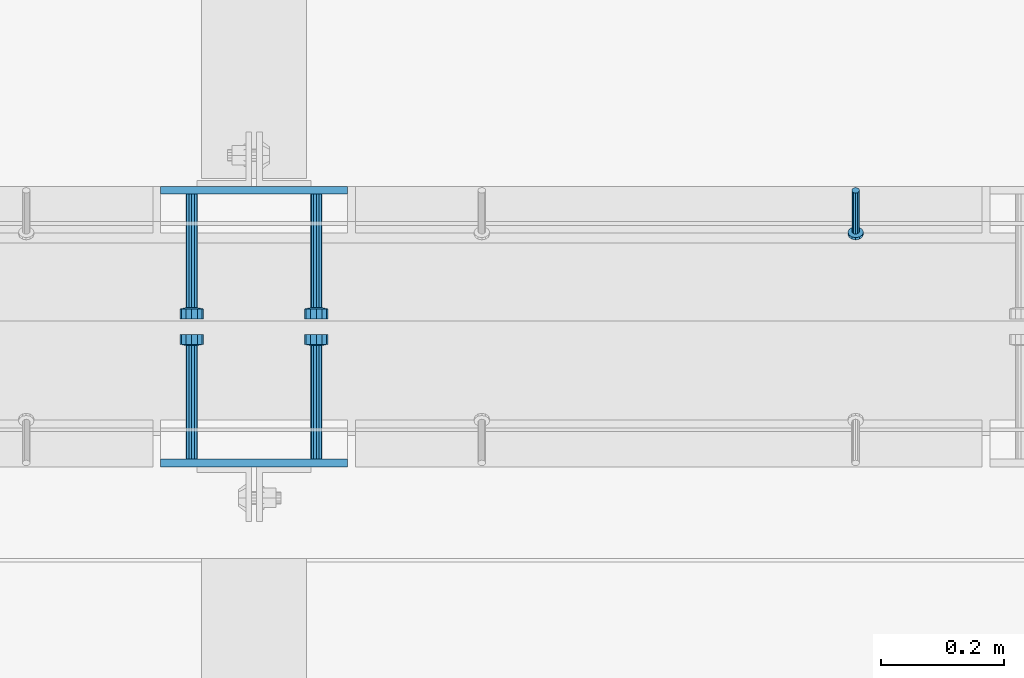
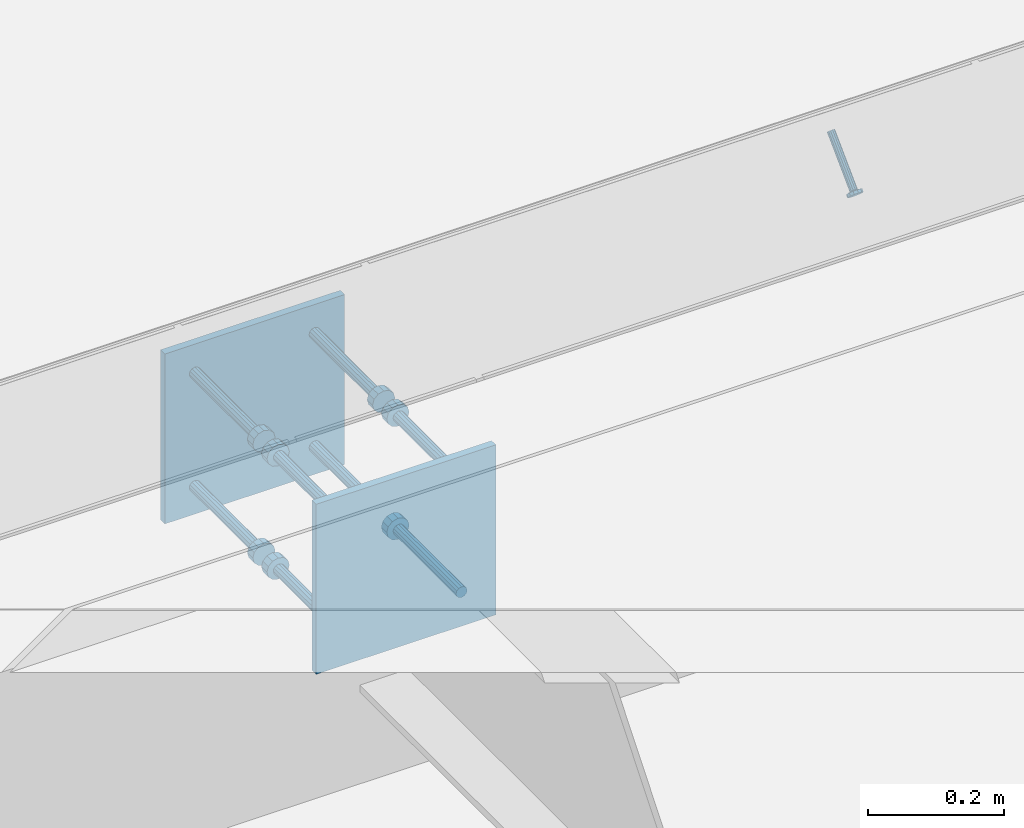
# One storey, part 2011 of 3843: 10 beams, 1 member, 3 elements without a shape of their own.
"""IFC2X3 building model written with IfcOpenShell, lengths in millimetres."""

from ifc_helpers import new_model, si_unit, frame, origin_with_axes, place, context, subcontext, project, spatial, faceted_brep, material, type_object, element, aggregate, save


model = new_model("IFC2X3")

# Units and contexts
model_context = context("Model", 3, precision=1e-05, world=origin_with_axes())
body_context = subcontext(model_context, "Body", "Model", "MODEL_VIEW")
ifc_project = project(units=[si_unit("LENGTHUNIT", "METRE", prefix="MILLI"), si_unit("AREAUNIT", "SQUARE_METRE"), si_unit("VOLUMEUNIT", "CUBIC_METRE"), si_unit("MASSUNIT", "GRAM", prefix="KILO"), si_unit("TIMEUNIT", "SECOND"), si_unit("PLANEANGLEUNIT", "RADIAN"), si_unit("SOLIDANGLEUNIT", "STERADIAN"), si_unit("THERMODYNAMICTEMPERATUREUNIT", "DEGREE_CELSIUS"), si_unit("LUMINOUSINTENSITYUNIT", "LUMEN")], contexts=[model_context])

# Site, building, storey
site_placement = place(None, origin_with_axes())
site = spatial("IfcSite", under=ifc_project, at=site_placement, CompositionType="ELEMENT")
building_placement = place(site_placement, origin_with_axes())
building = spatial("IfcBuilding", under=site, at=building_placement, Name="Undefined", CompositionType="ELEMENT")
storey_placement = place(building_placement, origin_with_axes())
storey = spatial("IfcBuildingStorey", under=building, at=storey_placement, Name="Undefined", CompositionType="ELEMENT", Elevation=0.0)

# Assembly, member
assembly_1_placement = place(storey_placement, origin_with_axes())
assembly_1 = element("IfcElementAssembly", 1, at=assembly_1_placement, inside=storey, Name="ANGLE", AssemblyPlace="NOTDEFINED", PredefinedType="RIGID_FRAME")
ifc_material_1 = material(Name="STEEL/A108")
member_type = type_object("IfcMemberType", PredefinedType="NOTDEFINED")
member_placement = place(assembly_1_placement, frame((45104.0772929978, 20456.5250055596, 30397.4500030518), z_axis=(1.0, 0.0, 0.0), x_axis=(0.0, -0.707106781186548, -0.707106781186548)))
member = element("IfcMember", 2, at=member_placement, type_object=member_type, material=ifc_material_1, Name="HEADED STUD ANCHOR", context=body_context, shape_type="Brep", body=[
    faceted_brep([(7.27595761418343e-12, -3.18000006675175, 5.5), (0.0, -5.49999999998363, 3.1800000667572), (94.4879985803855, -5.50000000011278, 3.1800000667572), (94.4879985803782, -3.18000006687362, 5.5), (0.0, -6.3499999046162, 0.0), (94.4879985803855, -6.34999990474535, 0.0), (0.0, -5.49999999998363, -3.1800000667572), (94.4879985803855, -5.50000000011278, -3.1800000667572), (7.27595761418343e-12, -3.18000006675175, -5.5), (94.4879985803782, -3.18000006687362, -5.5), (7.27595761418343e-12, -1.81898940354586e-12, -6.34999990463257), (94.4879985803782, -1.20053300634027e-10, -6.34999990463257), (0.0, 3.18000006675175, -5.5), (94.4879985803709, 3.18000006663351, -5.5), (7.27595761418343e-12, 5.49999999998363, -3.1800000667572), (94.4879985803709, 5.49999999987267, -3.1800000667572), (7.27595761418343e-12, 6.3499999046162, 0.0), (94.4879985803673, 6.34999990450706, 0.0), (7.27595761418343e-12, 5.49999999998363, 3.1800000667572), (94.4879985803709, 5.49999999987267, 3.1800000667572), (0.0, 3.18000006675175, 5.5), (94.4879985803709, 3.18000006663351, 5.5), (7.27595761418343e-12, -1.81898940354586e-12, 6.34999990463257), (94.4879985803782, -1.20053300634027e-10, 6.34999990463257), (96.5199985498621, -10.9899997712273, 6.34999990463257), (96.5199985498548, -6.34000015270249, 10.9899997711182), (96.5199985498621, -12.6999998093743, 0.0), (96.5199985498621, -10.9899997712273, -6.34999990463257), (96.5199985498548, -6.34000015270249, -10.9899997711182), (96.5199985498475, -1.21872290037572e-10, -12.6899995803833), (96.5199985498402, 6.34000015245874, -10.9899997711182), (96.519998549833, 10.9899997709817, -6.34999990463257), (96.519998549833, 12.6999998091305, 0.0), (96.519998549833, 10.9899997709817, 6.34999990463257), (96.5199985498402, 6.34000015245874, 10.9899997711182), (96.5199985498475, -1.21872290037572e-10, 12.6899995803833), (101.599998473539, -10.9899997712328, 6.34999990463257), (101.599998473532, -6.34000015270976, 10.9899997711182), (101.599998473539, -12.6999998093797, 0.0), (101.599998473539, -10.9899997712328, -6.34999990463257), (101.599998473532, -6.34000015270976, -10.9899997711182), (101.599998473524, -1.29148247651756e-10, -12.6899995803833), (101.599998473517, 6.34000015245329, -10.9899997711182), (101.59999847351, 10.9899997709763, -6.34999990463257), (101.599998473503, 12.6999998091196, 0.0), (101.59999847351, 10.9899997709763, 6.34999990463257), (101.599998473517, 6.34000015245329, 10.9899997711182), (101.599998473524, -1.29148247651756e-10, 12.6899995803833)], [[[0, 1, 2, 3]], [[1, 4, 5, 2]], [[4, 6, 7, 5]], [[6, 8, 9, 7]], [[8, 10, 11, 9]], [[10, 12, 13, 11]], [[12, 14, 15, 13]], [[14, 16, 17, 15]], [[16, 18, 19, 17]], [[18, 20, 21, 19]], [[20, 22, 23, 21]], [[22, 0, 3, 23]], [[22, 20, 18, 16, 14, 12, 10, 8, 6, 4, 1, 0]], [[3, 2, 24, 25]], [[2, 5, 26, 24]], [[5, 7, 27, 26]], [[7, 9, 28, 27]], [[9, 11, 29, 28]], [[11, 13, 30, 29]], [[13, 15, 31, 30]], [[15, 17, 32, 31]], [[17, 19, 33, 32]], [[19, 21, 34, 33]], [[21, 23, 35, 34]], [[23, 3, 25, 35]], [[25, 24, 36, 37]], [[24, 26, 38, 36]], [[26, 27, 39, 38]], [[27, 28, 40, 39]], [[28, 29, 41, 40]], [[29, 30, 42, 41]], [[30, 31, 43, 42]], [[31, 32, 44, 43]], [[32, 33, 45, 44]], [[33, 34, 46, 45]], [[34, 35, 47, 46]], [[35, 25, 37, 47]], [[38, 39, 40, 41, 42, 43, 44, 45, 46, 47, 37, 36]]]),
])
aggregate(assembly_1, [member])

# Assembly, beam
assembly_2_placement = place(storey_placement, origin_with_axes())
assembly_2 = element("IfcElementAssembly", 3, at=assembly_2_placement, inside=storey, Name="EMBED PLATE", AssemblyPlace="NOTDEFINED", PredefinedType="RIGID_FRAME")
ifc_material_2 = material(Name="STEEL/A36")
beam_type_1 = type_object("IfcBeamType", PredefinedType="NOTDEFINED")
beam_1_placement = place(assembly_2_placement, frame((44122.975, 20456.5250030517, 30397.45), z_axis=(-1.0, 0.0, 0.0), x_axis=(0.0, 0.0, -1.0)))
beam_1 = element("IfcBeam", 4, at=beam_1_placement, type_object=beam_type_1, material=ifc_material_2, Name="EMBED PLATE", context=body_context, shape_type="Brep", body=[
    faceted_brep([(-1.0550138540566e-10, 6.34999999999854, -152.400000000664), (1.0550138540566e-10, 6.34999999999854, 152.400000000656), (304.799999999999, 6.34999999999854, 152.400000000001), (304.799999999999, 6.34999999999854, -152.400000000001), (1.0550138540566e-10, -6.34999999999854, 152.400000000656), (304.799999999999, -6.34999999999854, 152.400000000001), (-1.0550138540566e-10, -6.34999999999854, -152.400000000664), (304.799999999999, -6.34999999999854, -152.400000000001)], [[[0, 1, 2, 3]], [[1, 4, 5, 2]], [[4, 6, 7, 5]], [[6, 0, 3, 7]], [[5, 7, 3, 2]], [[6, 4, 1, 0]]]),
])

assembly_3_placement = place(storey_placement, origin_with_axes())
assembly_3 = element("IfcElementAssembly", 5, at=assembly_3_placement, inside=storey, Name="EMBED PLATE", AssemblyPlace="NOTDEFINED", PredefinedType="RIGID_FRAME")
beam_2_placement = place(assembly_3_placement, frame((44122.975, 20012.0249969482, 30397.45), z_axis=(1.0, 0.0, 0.0), x_axis=(0.0, 0.0, -1.0)))
beam_2 = element("IfcBeam", 6, at=beam_2_placement, type_object=beam_type_1, material=ifc_material_2, Name="EMBED PLATE", context=body_context, shape_type="Brep", body=[
    faceted_brep([(-1.0550138540566e-10, 6.34999999999854, -152.400000000664), (1.0550138540566e-10, 6.34999999999854, 152.400000000656), (304.799999999999, 6.34999999999854, 152.400000000001), (304.799999999999, 6.34999999999854, -152.400000000001), (1.0550138540566e-10, -6.34999999999854, 152.400000000656), (304.799999999999, -6.34999999999854, 152.400000000001), (-1.0550138540566e-10, -6.34999999999854, -152.400000000664), (304.799999999999, -6.34999999999854, -152.400000000001)], [[[0, 1, 2, 3]], [[1, 4, 5, 2]], [[4, 6, 7, 5]], [[6, 0, 3, 7]], [[5, 7, 3, 2]], [[6, 4, 1, 0]]]),
])

# Beam
beam_type_2 = type_object("IfcBeamType", PredefinedType="NOTDEFINED")
beam_3_placement = place(assembly_2_placement, frame((44224.575, 20450.1750030517, 30346.65), z_axis=(1.0, 0.0, 0.0), x_axis=(0.0, -1.0, 0.0)))
beam_3 = element("IfcBeam", 7, at=beam_3_placement, type_object=beam_type_2, material=ifc_material_1, Name="HEADED STUD ANCHOR", context=body_context, shape_type="Brep", body=[
    faceted_brep([(0.0, -9.52000045776367, 0.0), (0.0, -8.25, -4.76000022888184), (184.912000000004, -8.25, -4.76000022888184), (184.912000000004, -9.52000045776367, 0.0), (0.0, -4.76000022888184, -8.25), (184.912000000004, -4.76000022888184, -8.25), (0.0, 0.0, -9.52000045776367), (184.912000000004, 0.0, -9.52000045776367), (0.0, 4.76000022888184, -8.25), (184.912000000004, 4.76000022888184, -8.25), (0.0, 8.25, -4.76000022888184), (184.912000000004, 8.25, -4.76000022888184), (0.0, 9.52000045776367, 0.0), (184.912000000004, 9.52000045776367, 0.0), (0.0, 8.25, 4.76000022888184), (184.912000000004, 8.25, 4.76000022888184), (0.0, 4.76000022888184, 8.25), (184.912000000004, 4.76000022888184, 8.25), (0.0, 0.0, 9.52000045776367), (184.912000000004, 0.0, 9.52000045776367), (0.0, -4.76000022888184, 8.25), (184.912000000004, -4.76000022888184, 8.25), (0.0, -8.25, 4.76000022888184), (184.912000000004, -8.25, 4.76000022888184), (186.944000000003, -16.5, -9.52000045776367), (186.944000000003, -19.0499992370605, 0.0), (186.944000000003, -9.52000045776367, -16.5), (186.944000000003, 0.0, -19.0499992370605), (186.944000000003, 9.52000045776367, -16.5), (186.944000000003, 16.5, -9.52000045776367), (186.944000000003, 19.0499992370605, 0.0), (186.944000000003, 16.5, 9.52000045776367), (186.944000000003, 9.52000045776367, 16.5), (186.944000000003, 0.0, 19.0499992370605), (186.944000000003, -9.52000045776367, 16.5), (186.944000000003, -16.5, 9.52000045776367), (203.199999999997, -16.5, -9.52000045776367), (203.199999999997, -19.0499992370605, 0.0), (203.199999999997, -9.52000045776367, -16.5), (203.199999999997, 0.0, -19.0499992370605), (203.199999999997, 9.52000045776367, -16.5), (203.199999999997, 16.5, -9.52000045776367), (203.199999999997, 19.0499992370605, 0.0), (203.199999999997, 16.5, 9.52000045776367), (203.199999999997, 9.52000045776367, 16.5), (203.199999999997, 0.0, 19.0499992370605), (203.199999999997, -9.52000045776367, 16.5), (203.199999999997, -16.5, 9.52000045776367)], [[[0, 1, 2, 3]], [[1, 4, 5, 2]], [[4, 6, 7, 5]], [[6, 8, 9, 7]], [[8, 10, 11, 9]], [[10, 12, 13, 11]], [[12, 14, 15, 13]], [[14, 16, 17, 15]], [[16, 18, 19, 17]], [[18, 20, 21, 19]], [[20, 22, 23, 21]], [[22, 0, 3, 23]], [[22, 20, 18, 16, 14, 12, 10, 8, 6, 4, 1, 0]], [[3, 2, 24, 25]], [[2, 5, 26, 24]], [[5, 7, 27, 26]], [[7, 9, 28, 27]], [[9, 11, 29, 28]], [[11, 13, 30, 29]], [[13, 15, 31, 30]], [[15, 17, 32, 31]], [[17, 19, 33, 32]], [[19, 21, 34, 33]], [[21, 23, 35, 34]], [[23, 3, 25, 35]], [[25, 24, 36, 37]], [[24, 26, 38, 36]], [[26, 27, 39, 38]], [[27, 28, 40, 39]], [[28, 29, 41, 40]], [[29, 30, 42, 41]], [[30, 31, 43, 42]], [[31, 32, 44, 43]], [[32, 33, 45, 44]], [[33, 34, 46, 45]], [[34, 35, 47, 46]], [[35, 25, 37, 47]], [[38, 39, 40, 41, 42, 43, 44, 45, 46, 47, 37, 36]]]),
])

beam_4_placement = place(assembly_2_placement, frame((44224.575, 20450.1750030517, 30143.45), z_axis=(1.0, 0.0, 0.0), x_axis=(0.0, -1.0, 0.0)))
beam_4 = element("IfcBeam", 8, at=beam_4_placement, type_object=beam_type_2, material=ifc_material_1, Name="HEADED STUD ANCHOR", context=body_context, shape_type="Brep", body=[
    faceted_brep([(0.0, -9.52000045776367, 0.0), (0.0, -8.25, -4.76000022888184), (184.912000000004, -8.25, -4.76000022888184), (184.912000000004, -9.52000045776367, 0.0), (0.0, -4.76000022888184, -8.25), (184.912000000004, -4.76000022888184, -8.25), (0.0, 0.0, -9.52000045776367), (184.912000000004, 0.0, -9.52000045776367), (0.0, 4.76000022888184, -8.25), (184.912000000004, 4.76000022888184, -8.25), (0.0, 8.25, -4.76000022888184), (184.912000000004, 8.25, -4.76000022888184), (0.0, 9.52000045776367, 0.0), (184.912000000004, 9.52000045776367, 0.0), (0.0, 8.25, 4.76000022888184), (184.912000000004, 8.25, 4.76000022888184), (0.0, 4.76000022888184, 8.25), (184.912000000004, 4.76000022888184, 8.25), (0.0, 0.0, 9.52000045776367), (184.912000000004, 0.0, 9.52000045776367), (0.0, -4.76000022888184, 8.25), (184.912000000004, -4.76000022888184, 8.25), (0.0, -8.25, 4.76000022888184), (184.912000000004, -8.25, 4.76000022888184), (186.944000000003, -16.5, -9.52000045776367), (186.944000000003, -19.0499992370605, 0.0), (186.944000000003, -9.52000045776367, -16.5), (186.944000000003, 0.0, -19.0499992370605), (186.944000000003, 9.52000045776367, -16.5), (186.944000000003, 16.5, -9.52000045776367), (186.944000000003, 19.0499992370605, 0.0), (186.944000000003, 16.5, 9.52000045776367), (186.944000000003, 9.52000045776367, 16.5), (186.944000000003, 0.0, 19.0499992370605), (186.944000000003, -9.52000045776367, 16.5), (186.944000000003, -16.5, 9.52000045776367), (203.199999999997, -16.5, -9.52000045776367), (203.199999999997, -19.0499992370605, 0.0), (203.199999999997, -9.52000045776367, -16.5), (203.199999999997, 0.0, -19.0499992370605), (203.199999999997, 9.52000045776367, -16.5), (203.199999999997, 16.5, -9.52000045776367), (203.199999999997, 19.0499992370605, 0.0), (203.199999999997, 16.5, 9.52000045776367), (203.199999999997, 9.52000045776367, 16.5), (203.199999999997, 0.0, 19.0499992370605), (203.199999999997, -9.52000045776367, 16.5), (203.199999999997, -16.5, 9.52000045776367)], [[[0, 1, 2, 3]], [[1, 4, 5, 2]], [[4, 6, 7, 5]], [[6, 8, 9, 7]], [[8, 10, 11, 9]], [[10, 12, 13, 11]], [[12, 14, 15, 13]], [[14, 16, 17, 15]], [[16, 18, 19, 17]], [[18, 20, 21, 19]], [[20, 22, 23, 21]], [[22, 0, 3, 23]], [[22, 20, 18, 16, 14, 12, 10, 8, 6, 4, 1, 0]], [[3, 2, 24, 25]], [[2, 5, 26, 24]], [[5, 7, 27, 26]], [[7, 9, 28, 27]], [[9, 11, 29, 28]], [[11, 13, 30, 29]], [[13, 15, 31, 30]], [[15, 17, 32, 31]], [[17, 19, 33, 32]], [[19, 21, 34, 33]], [[21, 23, 35, 34]], [[23, 3, 25, 35]], [[25, 24, 36, 37]], [[24, 26, 38, 36]], [[26, 27, 39, 38]], [[27, 28, 40, 39]], [[28, 29, 41, 40]], [[29, 30, 42, 41]], [[30, 31, 43, 42]], [[31, 32, 44, 43]], [[32, 33, 45, 44]], [[33, 34, 46, 45]], [[34, 35, 47, 46]], [[35, 25, 37, 47]], [[38, 39, 40, 41, 42, 43, 44, 45, 46, 47, 37, 36]]]),
])

beam_5_placement = place(assembly_2_placement, frame((44021.375, 20450.1750030517, 30346.65), z_axis=(1.0, 0.0, 0.0), x_axis=(0.0, -1.0, 0.0)))
beam_5 = element("IfcBeam", 9, at=beam_5_placement, type_object=beam_type_2, material=ifc_material_2, Name="PLATE", context=body_context, shape_type="Brep", body=[
    faceted_brep([(0.0, -9.52000045776367, 0.0), (0.0, -8.25, -4.76000022888184), (184.912000000004, -8.25, -4.76000022888184), (184.912000000004, -9.52000045776367, 0.0), (0.0, -4.76000022888184, -8.25), (184.912000000004, -4.76000022888184, -8.25), (0.0, 0.0, -9.52000045776367), (184.912000000004, 0.0, -9.52000045776367), (0.0, 4.76000022888184, -8.25), (184.912000000004, 4.76000022888184, -8.25), (0.0, 8.25, -4.76000022888184), (184.912000000004, 8.25, -4.76000022888184), (0.0, 9.52000045776367, 0.0), (184.912000000004, 9.52000045776367, 0.0), (0.0, 8.25, 4.76000022888184), (184.912000000004, 8.25, 4.76000022888184), (0.0, 4.76000022888184, 8.25), (184.912000000004, 4.76000022888184, 8.25), (0.0, 0.0, 9.52000045776367), (184.912000000004, 0.0, 9.52000045776367), (0.0, -4.76000022888184, 8.25), (184.912000000004, -4.76000022888184, 8.25), (0.0, -8.25, 4.76000022888184), (184.912000000004, -8.25, 4.76000022888184), (186.944000000003, -16.5, -9.52000045776367), (186.944000000003, -19.0499992370605, 0.0), (186.944000000003, -9.52000045776367, -16.5), (186.944000000003, 0.0, -19.0499992370605), (186.944000000003, 9.52000045776367, -16.5), (186.944000000003, 16.5, -9.52000045776367), (186.944000000003, 19.0499992370605, 0.0), (186.944000000003, 16.5, 9.52000045776367), (186.944000000003, 9.52000045776367, 16.5), (186.944000000003, 0.0, 19.0499992370605), (186.944000000003, -9.52000045776367, 16.5), (186.944000000003, -16.5, 9.52000045776367), (203.199999999997, -16.5, -9.52000045776367), (203.199999999997, -19.0499992370605, 0.0), (203.199999999997, -9.52000045776367, -16.5), (203.199999999997, 0.0, -19.0499992370605), (203.199999999997, 9.52000045776367, -16.5), (203.199999999997, 16.5, -9.52000045776367), (203.199999999997, 19.0499992370605, 0.0), (203.199999999997, 16.5, 9.52000045776367), (203.199999999997, 9.52000045776367, 16.5), (203.199999999997, 0.0, 19.0499992370605), (203.199999999997, -9.52000045776367, 16.5), (203.199999999997, -16.5, 9.52000045776367)], [[[0, 1, 2, 3]], [[1, 4, 5, 2]], [[4, 6, 7, 5]], [[6, 8, 9, 7]], [[8, 10, 11, 9]], [[10, 12, 13, 11]], [[12, 14, 15, 13]], [[14, 16, 17, 15]], [[16, 18, 19, 17]], [[18, 20, 21, 19]], [[20, 22, 23, 21]], [[22, 0, 3, 23]], [[22, 20, 18, 16, 14, 12, 10, 8, 6, 4, 1, 0]], [[3, 2, 24, 25]], [[2, 5, 26, 24]], [[5, 7, 27, 26]], [[7, 9, 28, 27]], [[9, 11, 29, 28]], [[11, 13, 30, 29]], [[13, 15, 31, 30]], [[15, 17, 32, 31]], [[17, 19, 33, 32]], [[19, 21, 34, 33]], [[21, 23, 35, 34]], [[23, 3, 25, 35]], [[25, 24, 36, 37]], [[24, 26, 38, 36]], [[26, 27, 39, 38]], [[27, 28, 40, 39]], [[28, 29, 41, 40]], [[29, 30, 42, 41]], [[30, 31, 43, 42]], [[31, 32, 44, 43]], [[32, 33, 45, 44]], [[33, 34, 46, 45]], [[34, 35, 47, 46]], [[35, 25, 37, 47]], [[38, 39, 40, 41, 42, 43, 44, 45, 46, 47, 37, 36]]]),
])

beam_6_placement = place(assembly_2_placement, frame((44021.375, 20450.1750030517, 30143.45), z_axis=(1.0, 0.0, 0.0), x_axis=(0.0, -1.0, 0.0)))
beam_6 = element("IfcBeam", 10, at=beam_6_placement, type_object=beam_type_2, material=ifc_material_1, Name="HEADED STUD ANCHOR", context=body_context, shape_type="Brep", body=[
    faceted_brep([(0.0, -9.52000045776367, 0.0), (0.0, -8.25, -4.76000022888184), (184.912000000004, -8.25, -4.76000022888184), (184.912000000004, -9.52000045776367, 0.0), (0.0, -4.76000022888184, -8.25), (184.912000000004, -4.76000022888184, -8.25), (0.0, 0.0, -9.52000045776367), (184.912000000004, 0.0, -9.52000045776367), (0.0, 4.76000022888184, -8.25), (184.912000000004, 4.76000022888184, -8.25), (0.0, 8.25, -4.76000022888184), (184.912000000004, 8.25, -4.76000022888184), (0.0, 9.52000045776367, 0.0), (184.912000000004, 9.52000045776367, 0.0), (0.0, 8.25, 4.76000022888184), (184.912000000004, 8.25, 4.76000022888184), (0.0, 4.76000022888184, 8.25), (184.912000000004, 4.76000022888184, 8.25), (0.0, 0.0, 9.52000045776367), (184.912000000004, 0.0, 9.52000045776367), (0.0, -4.76000022888184, 8.25), (184.912000000004, -4.76000022888184, 8.25), (0.0, -8.25, 4.76000022888184), (184.912000000004, -8.25, 4.76000022888184), (186.944000000003, -16.5, -9.52000045776367), (186.944000000003, -19.0499992370605, 0.0), (186.944000000003, -9.52000045776367, -16.5), (186.944000000003, 0.0, -19.0499992370605), (186.944000000003, 9.52000045776367, -16.5), (186.944000000003, 16.5, -9.52000045776367), (186.944000000003, 19.0499992370605, 0.0), (186.944000000003, 16.5, 9.52000045776367), (186.944000000003, 9.52000045776367, 16.5), (186.944000000003, 0.0, 19.0499992370605), (186.944000000003, -9.52000045776367, 16.5), (186.944000000003, -16.5, 9.52000045776367), (203.199999999997, -16.5, -9.52000045776367), (203.199999999997, -19.0499992370605, 0.0), (203.199999999997, -9.52000045776367, -16.5), (203.199999999997, 0.0, -19.0499992370605), (203.199999999997, 9.52000045776367, -16.5), (203.199999999997, 16.5, -9.52000045776367), (203.199999999997, 19.0499992370605, 0.0), (203.199999999997, 16.5, 9.52000045776367), (203.199999999997, 9.52000045776367, 16.5), (203.199999999997, 0.0, 19.0499992370605), (203.199999999997, -9.52000045776367, 16.5), (203.199999999997, -16.5, 9.52000045776367)], [[[0, 1, 2, 3]], [[1, 4, 5, 2]], [[4, 6, 7, 5]], [[6, 8, 9, 7]], [[8, 10, 11, 9]], [[10, 12, 13, 11]], [[12, 14, 15, 13]], [[14, 16, 17, 15]], [[16, 18, 19, 17]], [[18, 20, 21, 19]], [[20, 22, 23, 21]], [[22, 0, 3, 23]], [[22, 20, 18, 16, 14, 12, 10, 8, 6, 4, 1, 0]], [[3, 2, 24, 25]], [[2, 5, 26, 24]], [[5, 7, 27, 26]], [[7, 9, 28, 27]], [[9, 11, 29, 28]], [[11, 13, 30, 29]], [[13, 15, 31, 30]], [[15, 17, 32, 31]], [[17, 19, 33, 32]], [[19, 21, 34, 33]], [[21, 23, 35, 34]], [[23, 3, 25, 35]], [[25, 24, 36, 37]], [[24, 26, 38, 36]], [[26, 27, 39, 38]], [[27, 28, 40, 39]], [[28, 29, 41, 40]], [[29, 30, 42, 41]], [[30, 31, 43, 42]], [[31, 32, 44, 43]], [[32, 33, 45, 44]], [[33, 34, 46, 45]], [[34, 35, 47, 46]], [[35, 25, 37, 47]], [[38, 39, 40, 41, 42, 43, 44, 45, 46, 47, 37, 36]]]),
])

aggregate(assembly_2, [beam_3, beam_4, beam_5, beam_6, beam_1])

beam_7_placement = place(assembly_3_placement, frame((44021.375, 20018.3749969482, 30346.65), z_axis=(-1.0, 0.0, 0.0), x_axis=(0.0, 1.0, 0.0)))
beam_7 = element("IfcBeam", 11, at=beam_7_placement, type_object=beam_type_2, material=ifc_material_1, Name="HEADED STUD ANCHOR", context=body_context, shape_type="Brep", body=[
    faceted_brep([(0.0, -9.52000045776367, 0.0), (0.0, -8.25, -4.76000022888184), (184.912000000004, -8.25, -4.76000022888184), (184.912000000004, -9.52000045776367, 0.0), (0.0, -4.76000022888184, -8.25), (184.912000000004, -4.76000022888184, -8.25), (0.0, 0.0, -9.52000045776367), (184.912000000004, 0.0, -9.52000045776367), (0.0, 4.76000022888184, -8.25), (184.912000000004, 4.76000022888184, -8.25), (0.0, 8.25, -4.76000022888184), (184.912000000004, 8.25, -4.76000022888184), (0.0, 9.52000045776367, 0.0), (184.912000000004, 9.52000045776367, 0.0), (0.0, 8.25, 4.76000022888184), (184.912000000004, 8.25, 4.76000022888184), (0.0, 4.76000022888184, 8.25), (184.912000000004, 4.76000022888184, 8.25), (0.0, 0.0, 9.52000045776367), (184.912000000004, 0.0, 9.52000045776367), (0.0, -4.76000022888184, 8.25), (184.912000000004, -4.76000022888184, 8.25), (0.0, -8.25, 4.76000022888184), (184.912000000004, -8.25, 4.76000022888184), (186.944000000003, -16.5, -9.52000045776367), (186.944000000003, -19.0499992370605, 0.0), (186.944000000003, -9.52000045776367, -16.5), (186.944000000003, 0.0, -19.0499992370605), (186.944000000003, 9.52000045776367, -16.5), (186.944000000003, 16.5, -9.52000045776367), (186.944000000003, 19.0499992370605, 0.0), (186.944000000003, 16.5, 9.52000045776367), (186.944000000003, 9.52000045776367, 16.5), (186.944000000003, 0.0, 19.0499992370605), (186.944000000003, -9.52000045776367, 16.5), (186.944000000003, -16.5, 9.52000045776367), (203.199999999997, -16.5, -9.52000045776367), (203.199999999997, -19.0499992370605, 0.0), (203.199999999997, -9.52000045776367, -16.5), (203.199999999997, 0.0, -19.0499992370605), (203.199999999997, 9.52000045776367, -16.5), (203.199999999997, 16.5, -9.52000045776367), (203.199999999997, 19.0499992370605, 0.0), (203.199999999997, 16.5, 9.52000045776367), (203.199999999997, 9.52000045776367, 16.5), (203.199999999997, 0.0, 19.0499992370605), (203.199999999997, -9.52000045776367, 16.5), (203.199999999997, -16.5, 9.52000045776367)], [[[0, 1, 2, 3]], [[1, 4, 5, 2]], [[4, 6, 7, 5]], [[6, 8, 9, 7]], [[8, 10, 11, 9]], [[10, 12, 13, 11]], [[12, 14, 15, 13]], [[14, 16, 17, 15]], [[16, 18, 19, 17]], [[18, 20, 21, 19]], [[20, 22, 23, 21]], [[22, 0, 3, 23]], [[22, 20, 18, 16, 14, 12, 10, 8, 6, 4, 1, 0]], [[3, 2, 24, 25]], [[2, 5, 26, 24]], [[5, 7, 27, 26]], [[7, 9, 28, 27]], [[9, 11, 29, 28]], [[11, 13, 30, 29]], [[13, 15, 31, 30]], [[15, 17, 32, 31]], [[17, 19, 33, 32]], [[19, 21, 34, 33]], [[21, 23, 35, 34]], [[23, 3, 25, 35]], [[25, 24, 36, 37]], [[24, 26, 38, 36]], [[26, 27, 39, 38]], [[27, 28, 40, 39]], [[28, 29, 41, 40]], [[29, 30, 42, 41]], [[30, 31, 43, 42]], [[31, 32, 44, 43]], [[32, 33, 45, 44]], [[33, 34, 46, 45]], [[34, 35, 47, 46]], [[35, 25, 37, 47]], [[38, 39, 40, 41, 42, 43, 44, 45, 46, 47, 37, 36]]]),
])

beam_8_placement = place(assembly_3_placement, frame((44021.375, 20018.3749969482, 30143.45), z_axis=(-1.0, 0.0, 0.0), x_axis=(0.0, 1.0, 0.0)))
beam_8 = element("IfcBeam", 12, at=beam_8_placement, type_object=beam_type_2, material=ifc_material_1, Name="HEADED STUD ANCHOR", context=body_context, shape_type="Brep", body=[
    faceted_brep([(0.0, -9.52000045776367, 0.0), (0.0, -8.25, -4.76000022888184), (184.912000000004, -8.25, -4.76000022888184), (184.912000000004, -9.52000045776367, 0.0), (0.0, -4.76000022888184, -8.25), (184.912000000004, -4.76000022888184, -8.25), (0.0, 0.0, -9.52000045776367), (184.912000000004, 0.0, -9.52000045776367), (0.0, 4.76000022888184, -8.25), (184.912000000004, 4.76000022888184, -8.25), (0.0, 8.25, -4.76000022888184), (184.912000000004, 8.25, -4.76000022888184), (0.0, 9.52000045776367, 0.0), (184.912000000004, 9.52000045776367, 0.0), (0.0, 8.25, 4.76000022888184), (184.912000000004, 8.25, 4.76000022888184), (0.0, 4.76000022888184, 8.25), (184.912000000004, 4.76000022888184, 8.25), (0.0, 0.0, 9.52000045776367), (184.912000000004, 0.0, 9.52000045776367), (0.0, -4.76000022888184, 8.25), (184.912000000004, -4.76000022888184, 8.25), (0.0, -8.25, 4.76000022888184), (184.912000000004, -8.25, 4.76000022888184), (186.944000000003, -16.5, -9.52000045776367), (186.944000000003, -19.0499992370605, 0.0), (186.944000000003, -9.52000045776367, -16.5), (186.944000000003, 0.0, -19.0499992370605), (186.944000000003, 9.52000045776367, -16.5), (186.944000000003, 16.5, -9.52000045776367), (186.944000000003, 19.0499992370605, 0.0), (186.944000000003, 16.5, 9.52000045776367), (186.944000000003, 9.52000045776367, 16.5), (186.944000000003, 0.0, 19.0499992370605), (186.944000000003, -9.52000045776367, 16.5), (186.944000000003, -16.5, 9.52000045776367), (203.199999999997, -16.5, -9.52000045776367), (203.199999999997, -19.0499992370605, 0.0), (203.199999999997, -9.52000045776367, -16.5), (203.199999999997, 0.0, -19.0499992370605), (203.199999999997, 9.52000045776367, -16.5), (203.199999999997, 16.5, -9.52000045776367), (203.199999999997, 19.0499992370605, 0.0), (203.199999999997, 16.5, 9.52000045776367), (203.199999999997, 9.52000045776367, 16.5), (203.199999999997, 0.0, 19.0499992370605), (203.199999999997, -9.52000045776367, 16.5), (203.199999999997, -16.5, 9.52000045776367)], [[[0, 1, 2, 3]], [[1, 4, 5, 2]], [[4, 6, 7, 5]], [[6, 8, 9, 7]], [[8, 10, 11, 9]], [[10, 12, 13, 11]], [[12, 14, 15, 13]], [[14, 16, 17, 15]], [[16, 18, 19, 17]], [[18, 20, 21, 19]], [[20, 22, 23, 21]], [[22, 0, 3, 23]], [[22, 20, 18, 16, 14, 12, 10, 8, 6, 4, 1, 0]], [[3, 2, 24, 25]], [[2, 5, 26, 24]], [[5, 7, 27, 26]], [[7, 9, 28, 27]], [[9, 11, 29, 28]], [[11, 13, 30, 29]], [[13, 15, 31, 30]], [[15, 17, 32, 31]], [[17, 19, 33, 32]], [[19, 21, 34, 33]], [[21, 23, 35, 34]], [[23, 3, 25, 35]], [[25, 24, 36, 37]], [[24, 26, 38, 36]], [[26, 27, 39, 38]], [[27, 28, 40, 39]], [[28, 29, 41, 40]], [[29, 30, 42, 41]], [[30, 31, 43, 42]], [[31, 32, 44, 43]], [[32, 33, 45, 44]], [[33, 34, 46, 45]], [[34, 35, 47, 46]], [[35, 25, 37, 47]], [[38, 39, 40, 41, 42, 43, 44, 45, 46, 47, 37, 36]]]),
])

beam_9_placement = place(assembly_3_placement, frame((44224.575, 20018.3749969482, 30346.65), z_axis=(-1.0, 0.0, 0.0), x_axis=(0.0, 1.0, 0.0)))
beam_9 = element("IfcBeam", 13, at=beam_9_placement, type_object=beam_type_2, material=ifc_material_2, Name="PLATE", context=body_context, shape_type="Brep", body=[
    faceted_brep([(0.0, -9.52000045776367, 0.0), (0.0, -8.25, -4.76000022888184), (184.912000000004, -8.25, -4.76000022888184), (184.912000000004, -9.52000045776367, 0.0), (0.0, -4.76000022888184, -8.25), (184.912000000004, -4.76000022888184, -8.25), (0.0, 0.0, -9.52000045776367), (184.912000000004, 0.0, -9.52000045776367), (0.0, 4.76000022888184, -8.25), (184.912000000004, 4.76000022888184, -8.25), (0.0, 8.25, -4.76000022888184), (184.912000000004, 8.25, -4.76000022888184), (0.0, 9.52000045776367, 0.0), (184.912000000004, 9.52000045776367, 0.0), (0.0, 8.25, 4.76000022888184), (184.912000000004, 8.25, 4.76000022888184), (0.0, 4.76000022888184, 8.25), (184.912000000004, 4.76000022888184, 8.25), (0.0, 0.0, 9.52000045776367), (184.912000000004, 0.0, 9.52000045776367), (0.0, -4.76000022888184, 8.25), (184.912000000004, -4.76000022888184, 8.25), (0.0, -8.25, 4.76000022888184), (184.912000000004, -8.25, 4.76000022888184), (186.944000000003, -16.5, -9.52000045776367), (186.944000000003, -19.0499992370605, 0.0), (186.944000000003, -9.52000045776367, -16.5), (186.944000000003, 0.0, -19.0499992370605), (186.944000000003, 9.52000045776367, -16.5), (186.944000000003, 16.5, -9.52000045776367), (186.944000000003, 19.0499992370605, 0.0), (186.944000000003, 16.5, 9.52000045776367), (186.944000000003, 9.52000045776367, 16.5), (186.944000000003, 0.0, 19.0499992370605), (186.944000000003, -9.52000045776367, 16.5), (186.944000000003, -16.5, 9.52000045776367), (203.199999999997, -16.5, -9.52000045776367), (203.199999999997, -19.0499992370605, 0.0), (203.199999999997, -9.52000045776367, -16.5), (203.199999999997, 0.0, -19.0499992370605), (203.199999999997, 9.52000045776367, -16.5), (203.199999999997, 16.5, -9.52000045776367), (203.199999999997, 19.0499992370605, 0.0), (203.199999999997, 16.5, 9.52000045776367), (203.199999999997, 9.52000045776367, 16.5), (203.199999999997, 0.0, 19.0499992370605), (203.199999999997, -9.52000045776367, 16.5), (203.199999999997, -16.5, 9.52000045776367)], [[[0, 1, 2, 3]], [[1, 4, 5, 2]], [[4, 6, 7, 5]], [[6, 8, 9, 7]], [[8, 10, 11, 9]], [[10, 12, 13, 11]], [[12, 14, 15, 13]], [[14, 16, 17, 15]], [[16, 18, 19, 17]], [[18, 20, 21, 19]], [[20, 22, 23, 21]], [[22, 0, 3, 23]], [[22, 20, 18, 16, 14, 12, 10, 8, 6, 4, 1, 0]], [[3, 2, 24, 25]], [[2, 5, 26, 24]], [[5, 7, 27, 26]], [[7, 9, 28, 27]], [[9, 11, 29, 28]], [[11, 13, 30, 29]], [[13, 15, 31, 30]], [[15, 17, 32, 31]], [[17, 19, 33, 32]], [[19, 21, 34, 33]], [[21, 23, 35, 34]], [[23, 3, 25, 35]], [[25, 24, 36, 37]], [[24, 26, 38, 36]], [[26, 27, 39, 38]], [[27, 28, 40, 39]], [[28, 29, 41, 40]], [[29, 30, 42, 41]], [[30, 31, 43, 42]], [[31, 32, 44, 43]], [[32, 33, 45, 44]], [[33, 34, 46, 45]], [[34, 35, 47, 46]], [[35, 25, 37, 47]], [[38, 39, 40, 41, 42, 43, 44, 45, 46, 47, 37, 36]]]),
])

beam_10_placement = place(assembly_3_placement, frame((44224.575, 20018.3749969482, 30143.45), z_axis=(-1.0, 0.0, 0.0), x_axis=(0.0, 1.0, 0.0)))
beam_10 = element("IfcBeam", 14, at=beam_10_placement, type_object=beam_type_2, material=ifc_material_1, Name="HEADED STUD ANCHOR", context=body_context, shape_type="Brep", body=[
    faceted_brep([(0.0, -9.52000045776367, 0.0), (0.0, -8.25, -4.76000022888184), (184.912000000004, -8.25, -4.76000022888184), (184.912000000004, -9.52000045776367, 0.0), (0.0, -4.76000022888184, -8.25), (184.912000000004, -4.76000022888184, -8.25), (0.0, 0.0, -9.52000045776367), (184.912000000004, 0.0, -9.52000045776367), (0.0, 4.76000022888184, -8.25), (184.912000000004, 4.76000022888184, -8.25), (0.0, 8.25, -4.76000022888184), (184.912000000004, 8.25, -4.76000022888184), (0.0, 9.52000045776367, 0.0), (184.912000000004, 9.52000045776367, 0.0), (0.0, 8.25, 4.76000022888184), (184.912000000004, 8.25, 4.76000022888184), (0.0, 4.76000022888184, 8.25), (184.912000000004, 4.76000022888184, 8.25), (0.0, 0.0, 9.52000045776367), (184.912000000004, 0.0, 9.52000045776367), (0.0, -4.76000022888184, 8.25), (184.912000000004, -4.76000022888184, 8.25), (0.0, -8.25, 4.76000022888184), (184.912000000004, -8.25, 4.76000022888184), (186.944000000003, -16.5, -9.52000045776367), (186.944000000003, -19.0499992370605, 0.0), (186.944000000003, -9.52000045776367, -16.5), (186.944000000003, 0.0, -19.0499992370605), (186.944000000003, 9.52000045776367, -16.5), (186.944000000003, 16.5, -9.52000045776367), (186.944000000003, 19.0499992370605, 0.0), (186.944000000003, 16.5, 9.52000045776367), (186.944000000003, 9.52000045776367, 16.5), (186.944000000003, 0.0, 19.0499992370605), (186.944000000003, -9.52000045776367, 16.5), (186.944000000003, -16.5, 9.52000045776367), (203.199999999997, -16.5, -9.52000045776367), (203.199999999997, -19.0499992370605, 0.0), (203.199999999997, -9.52000045776367, -16.5), (203.199999999997, 0.0, -19.0499992370605), (203.199999999997, 9.52000045776367, -16.5), (203.199999999997, 16.5, -9.52000045776367), (203.199999999997, 19.0499992370605, 0.0), (203.199999999997, 16.5, 9.52000045776367), (203.199999999997, 9.52000045776367, 16.5), (203.199999999997, 0.0, 19.0499992370605), (203.199999999997, -9.52000045776367, 16.5), (203.199999999997, -16.5, 9.52000045776367)], [[[0, 1, 2, 3]], [[1, 4, 5, 2]], [[4, 6, 7, 5]], [[6, 8, 9, 7]], [[8, 10, 11, 9]], [[10, 12, 13, 11]], [[12, 14, 15, 13]], [[14, 16, 17, 15]], [[16, 18, 19, 17]], [[18, 20, 21, 19]], [[20, 22, 23, 21]], [[22, 0, 3, 23]], [[22, 20, 18, 16, 14, 12, 10, 8, 6, 4, 1, 0]], [[3, 2, 24, 25]], [[2, 5, 26, 24]], [[5, 7, 27, 26]], [[7, 9, 28, 27]], [[9, 11, 29, 28]], [[11, 13, 30, 29]], [[13, 15, 31, 30]], [[15, 17, 32, 31]], [[17, 19, 33, 32]], [[19, 21, 34, 33]], [[21, 23, 35, 34]], [[23, 3, 25, 35]], [[25, 24, 36, 37]], [[24, 26, 38, 36]], [[26, 27, 39, 38]], [[27, 28, 40, 39]], [[28, 29, 41, 40]], [[29, 30, 42, 41]], [[30, 31, 43, 42]], [[31, 32, 44, 43]], [[32, 33, 45, 44]], [[33, 34, 46, 45]], [[34, 35, 47, 46]], [[35, 25, 37, 47]], [[38, 39, 40, 41, 42, 43, 44, 45, 46, 47, 37, 36]]]),
])

aggregate(assembly_3, [beam_7, beam_8, beam_9, beam_10, beam_2])

save(model, "model.ifc")
